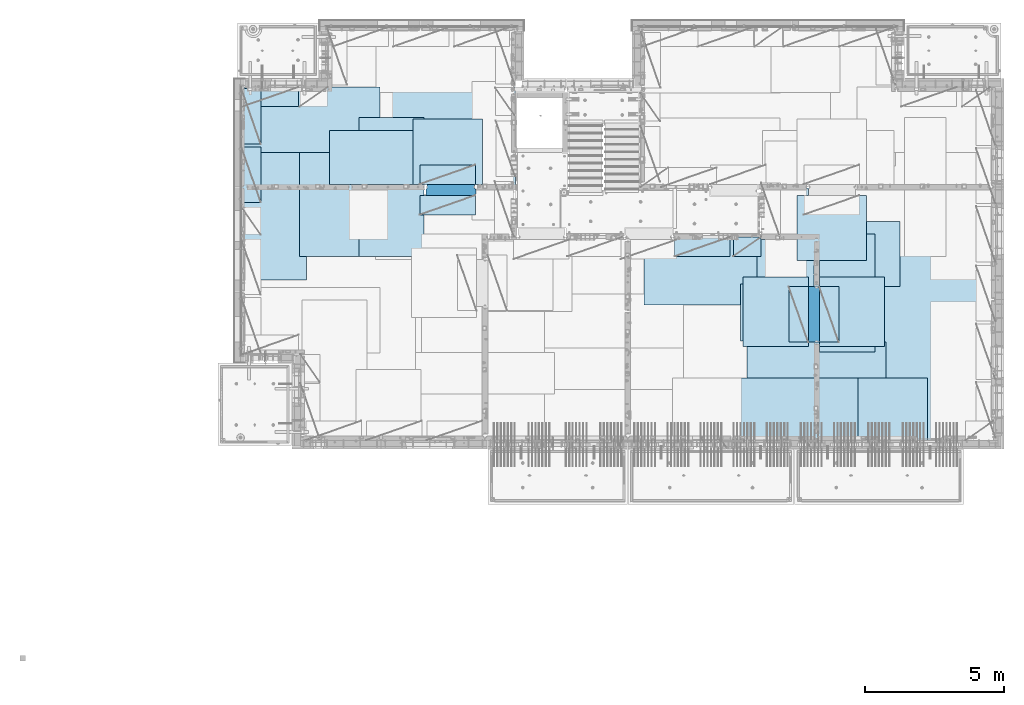
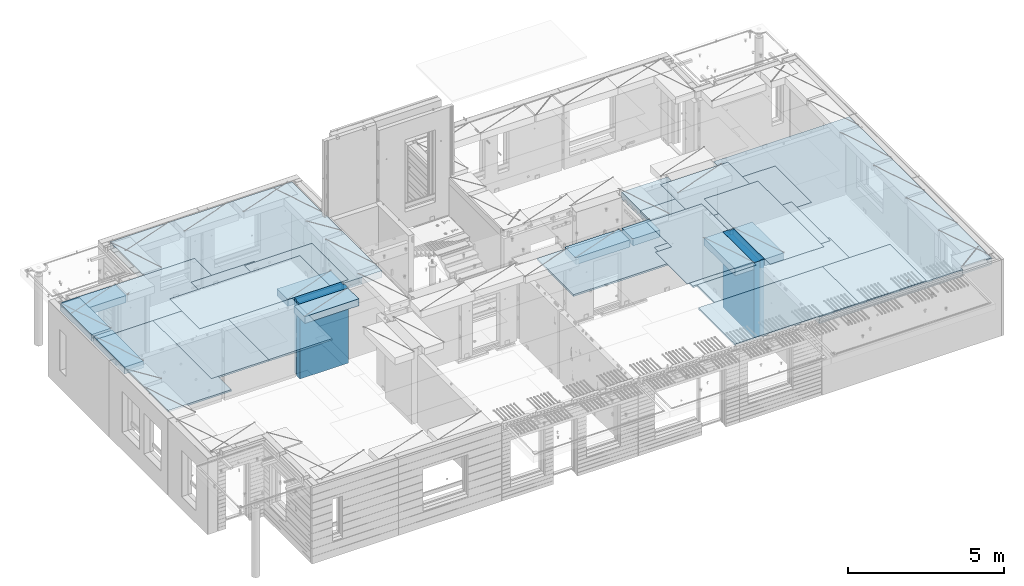
# One storey, part 203 of 352: 27 plates, 2 slabs, 25 elements without a shape of their own.
"""IFC2X3 building model written with IfcOpenShell, lengths in millimetres."""

from ifc_helpers import new_model, si_unit, frame, origin_with_axes, place, context, subcontext, project, spatial, faceted_brep, material, type_object, element, aggregate, save


model = new_model("IFC2X3")

# Units and contexts
model_context = context("Model", 3, precision=1e-05, world=origin_with_axes())
body_context = subcontext(model_context, "Body", "Model", "MODEL_VIEW")
ifc_project = project(units=[si_unit("LENGTHUNIT", "METRE", prefix="MILLI"), si_unit("AREAUNIT", "SQUARE_METRE"), si_unit("VOLUMEUNIT", "CUBIC_METRE"), si_unit("MASSUNIT", "GRAM", prefix="KILO"), si_unit("TIMEUNIT", "SECOND"), si_unit("PLANEANGLEUNIT", "RADIAN"), si_unit("SOLIDANGLEUNIT", "STERADIAN"), si_unit("THERMODYNAMICTEMPERATUREUNIT", "DEGREE_CELSIUS"), si_unit("LUMINOUSINTENSITYUNIT", "LUMEN")], contexts=[model_context])

# Site, building, storey
site_placement = place(None, origin_with_axes())
site = spatial("IfcSite", under=ifc_project, at=site_placement, CompositionType="ELEMENT")
building_placement = place(site_placement, origin_with_axes())
building = spatial("IfcBuilding", under=site, at=building_placement, CompositionType="ELEMENT")
storey_placement = place(building_placement, origin_with_axes())
storey = spatial("IfcBuildingStorey", under=building, at=storey_placement, Name="6", CompositionType="ELEMENT", Elevation=0.0)

# Assembly, slabs
assembly_1_placement = place(storey_placement, origin_with_axes())
assembly_1 = element("IfcElementAssembly", 1, at=assembly_1_placement, inside=storey, AssemblyPlace="NOTDEFINED", PredefinedType="REINFORCEMENT_UNIT")
ifc_material_1 = material(Name="CONCRETE/C30/37")
slab_type_1 = type_object("IfcSlabType", PredefinedType="NOTDEFINED")
slab_1_placement = place(assembly_1_placement, frame((7880.0, 16980.0, 99595.0), z_axis=(0.0, 1.0, 0.0), x_axis=(1.0, 0.0, 0.0)))
slab_1 = element("IfcSlab", 2, at=slab_1_placement, type_object=slab_type_1, material=ifc_material_1, PredefinedType="FLOOR", context=body_context, shape_type="Brep", body=[
    faceted_brep([(6583.68914550781, -135.0, 0.0), (6583.68914550781, 135.0, 0.0), (6583.68914550781, 135.0, 100.0), (6583.68914550781, -135.0, 100.0), (6649.99914550781, -135.0, 99.9997787475586), (6649.99914550781, 135.0, 99.9997787475586), (1.81898940354586e-12, -135.0, 1.81898940354586e-12), (-0.0001220703125, -135.0, 3600.0), (-0.0001220703125, 135.0, 3600.0), (1.81898940354586e-12, 135.0, 1.81898940354586e-12), (3110.00024414063, -135.0, 3600.0), (3110.00024414063, 135.0, 3600.0), (3110.00024414063, -135.0, 5760.0), (3110.00024414063, 135.0, 5760.0), (9850.0009765625, -135.0, 5760.0), (9850.0009765625, 135.0, 5760.0), (9850.0009765625, -135.0, 3600.0), (9850.0009765625, 135.0, 3600.0), (9870.0, -135.0, 3600.0), (9870.0, 135.0, 3600.0), (9870.0, -135.0, 0.0), (9870.0, 135.0, 0.0), (8449.99914550781, -135.0, 0.0), (8449.99914550781, 135.0, 0.0), (8449.99914550781, -135.0, 99.9997787475586), (8449.99914550781, 135.0, 99.9997787475586), (8283.68914550781, -135.0, 99.9997787475586), (8283.68914550781, 135.0, 99.9997787475586)], [[[0, 1, 2, 3]], [[4, 3, 2, 5]], [[6, 7, 8, 9]], [[7, 10, 11, 8]], [[10, 12, 13, 11]], [[12, 14, 15, 13]], [[14, 16, 17, 15]], [[16, 18, 19, 17]], [[18, 20, 21, 19]], [[21, 20, 22, 23]], [[24, 25, 23, 22]], [[26, 4, 5, 27, 25, 24]], [[1, 9, 8, 11, 13, 15, 17, 19, 21, 23, 25, 27, 5, 2]], [[6, 9, 1, 0]], [[26, 24, 22, 20, 18, 16, 14, 12, 10, 7, 6, 0, 3, 4]]]),
])
slab_type_2 = type_object("IfcSlabType", PredefinedType="NOTDEFINED")
slab_2_placement = place(assembly_1_placement, frame((28610.0, 7708.0, 99595.0), z_axis=(0.0, 1.0, 0.0), x_axis=(1.0, 0.0, 0.0)))
slab_2 = element("IfcSlab", 3, at=slab_2_placement, type_object=slab_type_2, material=ifc_material_1, PredefinedType="FLOOR", context=body_context, shape_type="Brep", body=[
    faceted_brep([(0.0, -135.0, 7430.0), (0.0, 135.0, 7430.0), (0.0, 135.0, 5722.0), (0.0, -135.0, 5722.0), (-1999.99938964844, -135.0, 7430.0), (-1999.99938964844, 135.0, 7430.0), (-1999.99938964844, -135.0, 9230.0), (-1999.99938964844, 135.0, 9230.0), (-300.000239723071, -135.0, 9230.0), (-300.000239723071, 135.0, 9230.0), (-300.00008947117, -135.0, 8972.00002930513), (-300.00008947117, 135.0, 8972.00002930513), (1385.00027673977, -135.0, 8972.00002930513), (1400.0006429507, -135.0, 8972.00002930513), (1400.0006429507, 135.0, 8972.00002930513), (1385.00027673977, 135.0, 8972.00002930513), (1400.0006429507, -135.0, 9230.0), (1400.0006429507, 135.0, 9230.0), (6449.99951171875, -135.0, 9230.0), (6449.99951171875, 135.0, 9230.0), (6449.99951171875, -135.0, 100.00023651123), (6449.99951171875, 135.0, 100.00023651123), (5318.0, -135.0, 100.0), (5318.0, 135.0, 100.0), (5318.0, -135.0, -8.68840288603678e-09), (5318.0, 135.0, -8.68840288603678e-09), (1.81898940354586e-12, -135.0, 1.81898940354586e-12), (1.81898940354586e-12, 135.0, 1.81898940354586e-12), (0.0, 135.0, 3679.99963378906), (100.00089263916, 135.0, 3679.99963378906), (100.00089263916, 135.0, 3822.0), (100.00089263916, 135.0, 5679.99963378906), (100.00089263916, 135.0, 5722.0), (100.00089263916, -135.0, 5722.0), (100.00089263916, -135.0, 3822.0), (100.00089263916, -135.0, 3679.99963378906), (0.0, -135.0, 3679.99963378906), (100.00089263916, -135.0, 5679.99963378906)], [[[0, 1, 2, 3]], [[0, 4, 5, 1]], [[4, 6, 7, 5]], [[7, 6, 8, 9]], [[8, 10, 11, 9]], [[12, 13, 14, 15, 11, 10]], [[16, 17, 14, 13]], [[18, 19, 17, 16]], [[18, 20, 21, 19]], [[20, 22, 23, 21]], [[22, 24, 25, 23]], [[24, 26, 27, 25]], [[1, 5, 7, 9, 11, 15, 14, 17, 19, 21, 23, 25, 27, 28, 29, 30, 31, 32, 2]], [[3, 2, 32, 33]], [[34, 35, 36, 26, 24, 22, 20, 18, 16, 13, 12, 10, 8, 6, 4, 0, 3, 33, 37]], [[27, 26, 36, 28]], [[35, 29, 28, 36]], [[34, 37, 31, 30, 29, 35]], [[33, 32, 31, 37]]]),
])

# Assembly, plate
assembly_2_placement = place(storey_placement, origin_with_axes())
assembly_2 = element("IfcElementAssembly", 4, at=assembly_2_placement, inside=storey, Name="Steel Assembly", AssemblyPlace="NOTDEFINED", PredefinedType="NOTDEFINED")
ifc_material_2 = material()
plate_type_1 = type_object("IfcPlateType", PredefinedType="NOTDEFINED")
plate_1_placement = place(assembly_2_placement, frame((27902.5000293051, 16680.0, 99695.1), z_axis=(1.0, 0.0, 0.0), x_axis=(0.0, -1.0, 0.0)))
plate_1 = element("IfcPlate", 5, at=plate_1_placement, type_object=plate_type_1, material=ifc_material_2, Name="1/2", context=body_context, shape_type="Brep", body=[
    faceted_brep([(0.0, -35.0, 0.0), (0.0, -35.0, 2500.0), (0.0, 35.0, 2500.0), (0.0, 35.0, 0.0), (2349.99951171875, -35.0, 2500.0), (2349.99951171875, 35.0, 2500.0), (2350.0, -35.0, 0.0), (2350.0, 35.0, 0.0)], [[[0, 1, 2, 3]], [[1, 4, 5, 2]], [[4, 6, 7, 5]], [[6, 0, 3, 7]], [[5, 7, 3, 2]], [[6, 4, 1, 0]]]),
])
aggregate(assembly_2, [plate_1])

assembly_3_placement = place(storey_placement, origin_with_axes())
assembly_3 = element("IfcElementAssembly", 6, at=assembly_3_placement, inside=storey, Name="Steel Assembly", AssemblyPlace="NOTDEFINED", PredefinedType="NOTDEFINED")
plate_2_placement = place(assembly_3_placement, frame((32610.0, 7750.0, 99695.1), z_axis=(-1.0, 3.00000001838171e-08, 0.0), x_axis=(0.0, 1.0, 0.0)))
plate_2 = element("IfcPlate", 7, at=plate_2_placement, type_object=plate_type_1, material=ifc_material_2, Name="1/2", context=body_context, shape_type="Brep", body=[
    faceted_brep([(0.0, -35.0, 0.0), (0.0, -35.0, 2500.0), (0.0, 35.0, 2500.0), (0.0, 35.0, 0.0), (2349.99951171875, -35.0, 2500.0), (2349.99951171875, 35.0, 2500.0), (2350.0, -35.0, 0.0), (2350.0, 35.0, 0.0)], [[[0, 1, 2, 3]], [[1, 4, 5, 2]], [[4, 6, 7, 5]], [[6, 0, 3, 7]], [[5, 7, 3, 2]], [[6, 4, 1, 0]]]),
])
aggregate(assembly_3, [plate_2])

assembly_4_placement = place(storey_placement, origin_with_axes())
assembly_4 = element("IfcElementAssembly", 8, at=assembly_4_placement, inside=storey, Name="Steel Assembly", AssemblyPlace="NOTDEFINED", PredefinedType="NOTDEFINED")
plate_3_placement = place(assembly_4_placement, frame((27395.0, 12730.0, 99695.1), z_axis=(-1.0, 3.00000001838171e-08, 0.0), x_axis=(0.0, 1.0, 0.0)))
plate_3 = element("IfcPlate", 9, at=plate_3_placement, type_object=plate_type_1, material=ifc_material_2, context=body_context, shape_type="Brep", body=[
    faceted_brep([(0.0, -35.0, 0.0), (0.0, -35.0, 5000.0), (0.0, 35.0, 5000.0), (0.0, 35.0, 0.0), (2349.99951171875, -35.0, 5000.0), (2349.99951171875, 35.0, 5000.0), (2350.0, -35.0, 0.0), (2350.0, 35.0, 0.0)], [[[0, 1, 2, 3]], [[1, 4, 5, 2]], [[4, 6, 7, 5]], [[6, 0, 3, 7]], [[5, 7, 3, 2]], [[6, 4, 1, 0]]]),
])
aggregate(assembly_4, [plate_3])

assembly_5_placement = place(storey_placement, origin_with_axes())
assembly_5 = element("IfcElementAssembly", 10, at=assembly_5_placement, inside=storey, Name="Steel Assembly", AssemblyPlace="NOTDEFINED", PredefinedType="NOTDEFINED")
plate_4_placement = place(assembly_5_placement, frame((28709.9995320312, 11230.0000289158, 99695.1), z_axis=(0.0, 1.0, 0.0), x_axis=(1.0, 0.0, 0.0)))
plate_4 = element("IfcPlate", 11, at=plate_4_placement, type_object=plate_type_1, material=ifc_material_2, Name="1/2", context=body_context, shape_type="Brep", body=[
    faceted_brep([(0.0, -35.0, 0.0), (0.0, -35.0, 2500.0), (0.0, 35.0, 2500.0), (0.0, 35.0, 0.0), (2349.99951171875, -35.0, 2500.0), (2349.99951171875, 35.0, 2500.0), (2350.0, -35.0, 0.0), (2350.0, 35.0, 0.0)], [[[0, 1, 2, 3]], [[1, 4, 5, 2]], [[4, 6, 7, 5]], [[6, 0, 3, 7]], [[5, 7, 3, 2]], [[6, 4, 1, 0]]]),
])
aggregate(assembly_5, [plate_4])

assembly_6_placement = place(storey_placement, origin_with_axes())
assembly_6 = element("IfcElementAssembly", 12, at=assembly_6_placement, inside=storey, Name="Steel Assembly", AssemblyPlace="NOTDEFINED", PredefinedType="NOTDEFINED")
plate_5_placement = place(assembly_6_placement, frame((25959.9995320312, 11230.0000289158, 99695.1), z_axis=(0.0, 1.0, 0.0), x_axis=(1.0, 0.0, 0.0)))
plate_5 = element("IfcPlate", 13, at=plate_5_placement, type_object=plate_type_1, material=ifc_material_2, Name="1/2", context=body_context, shape_type="Brep", body=[
    faceted_brep([(0.0, -35.0, 0.0), (0.0, -35.0, 2500.0), (0.0, 35.0, 2500.0), (0.0, 35.0, 0.0), (2349.99951171875, -35.0, 2500.0), (2349.99951171875, 35.0, 2500.0), (2350.0, -35.0, 0.0), (2350.0, 35.0, 0.0)], [[[0, 1, 2, 3]], [[1, 4, 5, 2]], [[4, 6, 7, 5]], [[6, 0, 3, 7]], [[5, 7, 3, 2]], [[6, 4, 1, 0]]]),
])
aggregate(assembly_6, [plate_5])

assembly_7_placement = place(storey_placement, origin_with_axes())
assembly_7 = element("IfcElementAssembly", 14, at=assembly_7_placement, inside=storey, Name="Steel Assembly", AssemblyPlace="NOTDEFINED", PredefinedType="NOTDEFINED")
plate_6_placement = place(assembly_7_placement, frame((7880.0, 20580.0, 99695.1), z_axis=(1.0, 0.0, 0.0), x_axis=(0.0, -1.0, 0.0)))
plate_6 = element("IfcPlate", 15, at=plate_6_placement, type_object=plate_type_1, material=ifc_material_2, context=body_context, shape_type="Brep", body=[
    faceted_brep([(0.0, -35.0, 0.0), (0.0, -35.0, 5000.0), (0.0, 35.0, 5000.0), (0.0, 35.0, 0.0), (2349.99951171875, -35.0, 5000.0), (2349.99951171875, 35.0, 5000.0), (2350.0, -35.0, 0.0), (2350.0, 35.0, 0.0)], [[[0, 1, 2, 3]], [[1, 4, 5, 2]], [[4, 6, 7, 5]], [[6, 0, 3, 7]], [[5, 7, 3, 2]], [[6, 4, 1, 0]]]),
])
aggregate(assembly_7, [plate_6])

assembly_8_placement = place(storey_placement, origin_with_axes())
assembly_8 = element("IfcElementAssembly", 16, at=assembly_8_placement, inside=storey, Name="Steel Assembly", AssemblyPlace="NOTDEFINED", PredefinedType="NOTDEFINED")
plate_7_placement = place(assembly_8_placement, frame((14063.69, 19430.0, 99695.1), z_axis=(1.0, 0.0, 0.0), x_axis=(0.0, -1.0, 0.0)))
plate_7 = element("IfcPlate", 17, at=plate_7_placement, type_object=plate_type_1, material=ifc_material_2, Name="1/2", context=body_context, shape_type="Brep", body=[
    faceted_brep([(0.0, -35.0, 0.0), (0.0, -35.0, 2500.0), (0.0, 35.0, 2500.0), (0.0, 35.0, 0.0), (2349.99951171875, -35.0, 2500.0), (2349.99951171875, 35.0, 2500.0), (2350.0, -35.0, 0.0), (2350.0, 35.0, 0.0)], [[[0, 1, 2, 3]], [[1, 4, 5, 2]], [[4, 6, 7, 5]], [[6, 0, 3, 7]], [[5, 7, 3, 2]], [[6, 4, 1, 0]]]),
])
aggregate(assembly_8, [plate_7])

assembly_9_placement = place(storey_placement, origin_with_axes())
assembly_9 = element("IfcElementAssembly", 18, at=assembly_9_placement, inside=storey, Name="Steel Assembly", AssemblyPlace="NOTDEFINED", PredefinedType="NOTDEFINED")
plate_8_placement = place(assembly_9_placement, frame((31610.0, 13388.0, 99695.1), z_axis=(-1.0, 3.00000001838171e-08, 0.0), x_axis=(0.0, 1.0, 0.0)))
plate_8 = element("IfcPlate", 19, at=plate_8_placement, type_object=plate_type_1, material=ifc_material_2, context=body_context, shape_type="Brep", body=[
    faceted_brep([(0.0, -35.0, 0.0), (0.0, -35.0, 5000.0), (0.0, 35.0, 5000.0), (0.0, 35.0, 0.0), (2349.99951171875, -35.0, 5000.0), (2349.99951171875, 35.0, 5000.0), (2350.0, -35.0, 0.0), (2350.0, 35.0, 0.0)], [[[0, 1, 2, 3]], [[1, 4, 5, 2]], [[4, 6, 7, 5]], [[6, 0, 3, 7]], [[5, 7, 3, 2]], [[6, 4, 1, 0]]]),
])
aggregate(assembly_9, [plate_8])

assembly_10_placement = place(storey_placement, origin_with_axes())
assembly_10 = element("IfcElementAssembly", 20, at=assembly_10_placement, inside=storey, Name="Steel Assembly", AssemblyPlace="NOTDEFINED", PredefinedType="NOTDEFINED")
plate_9_placement = place(assembly_10_placement, frame((31110.0, 9038.0, 99695.1), z_axis=(-1.0, 3.00000001838171e-08, 0.0), x_axis=(0.0, 1.0, 0.0)))
plate_9 = element("IfcPlate", 21, at=plate_9_placement, type_object=plate_type_1, material=ifc_material_2, context=body_context, shape_type="Brep", body=[
    faceted_brep([(0.0, -35.0, 0.0), (0.0, -35.0, 5000.0), (0.0, 35.0, 5000.0), (0.0, 35.0, 0.0), (2349.99951171875, -35.0, 5000.0), (2349.99951171875, 35.0, 5000.0), (2350.0, -35.0, 0.0), (2350.0, 35.0, 0.0)], [[[0, 1, 2, 3]], [[1, 4, 5, 2]], [[4, 6, 7, 5]], [[6, 0, 3, 7]], [[5, 7, 3, 2]], [[6, 4, 1, 0]]]),
])
aggregate(assembly_10, [plate_9])

assembly_11_placement = place(storey_placement, origin_with_axes())
assembly_11 = element("IfcElementAssembly", 22, at=assembly_11_placement, inside=storey, Name="Steel Assembly", AssemblyPlace="NOTDEFINED", PredefinedType="NOTDEFINED")
plate_10_placement = place(assembly_11_placement, frame((30510.0, 7750.0, 99695.1), z_axis=(-1.0, 3.00000001838171e-08, 0.0), x_axis=(0.0, 1.0, 0.0)))
plate_10 = element("IfcPlate", 23, at=plate_10_placement, type_object=plate_type_1, material=ifc_material_2, context=body_context, shape_type="Brep", body=[
    faceted_brep([(0.0, -35.0, 0.0), (0.0, -35.0, 5000.0), (0.0, 35.0, 5000.0), (0.0, 35.0, 0.0), (2349.99951171875, -35.0, 5000.0), (2349.99951171875, 35.0, 5000.0), (2350.0, -35.0, 0.0), (2350.0, 35.0, 0.0)], [[[0, 1, 2, 3]], [[1, 4, 5, 2]], [[4, 6, 7, 5]], [[6, 0, 3, 7]], [[5, 7, 3, 2]], [[6, 4, 1, 0]]]),
])
aggregate(assembly_11, [plate_10])

assembly_12_placement = place(storey_placement, origin_with_axes())
assembly_12 = element("IfcElementAssembly", 24, at=assembly_12_placement, inside=storey, Name="Steel Assembly", AssemblyPlace="NOTDEFINED", PredefinedType="NOTDEFINED")
plate_11_placement = place(assembly_12_placement, frame((10230.0, 18627.0, 99695.1), z_axis=(0.0, -1.0, 0.0), x_axis=(-1.0, 3.00000001838171e-08, 0.0)))
plate_11 = element("IfcPlate", 25, at=plate_11_placement, type_object=plate_type_1, material=ifc_material_2, context=body_context, shape_type="Brep", body=[
    faceted_brep([(0.0, -35.0, 0.0), (0.0, -35.0, 5000.0), (0.0, 35.0, 5000.0), (0.0, 35.0, 0.0), (2349.99951171875, -35.0, 5000.0), (2349.99951171875, 35.0, 5000.0), (2350.0, -35.0, 0.0), (2350.0, 35.0, 0.0)], [[[0, 1, 2, 3]], [[1, 4, 5, 2]], [[4, 6, 7, 5]], [[6, 0, 3, 7]], [[5, 7, 3, 2]], [[6, 4, 1, 0]]]),
])
aggregate(assembly_12, [plate_11])

assembly_13_placement = place(storey_placement, origin_with_axes())
assembly_13 = element("IfcElementAssembly", 26, at=assembly_13_placement, inside=storey, Name="Steel Assembly", AssemblyPlace="NOTDEFINED", PredefinedType="NOTDEFINED")
plate_12_placement = place(assembly_13_placement, frame((14463.69, 19480.0, 99695.1), z_axis=(0.0, -1.0, 0.0), x_axis=(-1.0, 3.00000001838171e-08, 0.0)))
plate_12 = element("IfcPlate", 27, at=plate_12_placement, type_object=plate_type_1, material=ifc_material_2, context=body_context, shape_type="Brep", body=[
    faceted_brep([(0.0, -35.0, 0.0), (0.0, -35.0, 5000.0), (0.0, 35.0, 5000.0), (0.0, 35.0, 0.0), (2349.99951171875, -35.0, 5000.0), (2349.99951171875, 35.0, 5000.0), (2350.0, -35.0, 0.0), (2350.0, 35.0, 0.0)], [[[0, 1, 2, 3]], [[1, 4, 5, 2]], [[4, 6, 7, 5]], [[6, 0, 3, 7]], [[5, 7, 3, 2]], [[6, 4, 1, 0]]]),
])
aggregate(assembly_13, [plate_12])

assembly_14_placement = place(storey_placement, origin_with_axes())
assembly_14 = element("IfcElementAssembly", 28, at=assembly_14_placement, inside=storey, Name="Steel Assembly", AssemblyPlace="NOTDEFINED", PredefinedType="NOTDEFINED")
plate_13_placement = place(assembly_14_placement, frame((12330.0, 19480.0, 99695.1), z_axis=(0.0, -1.0, 0.0), x_axis=(-1.0, 3.00000001838171e-08, 0.0)))
plate_13 = element("IfcPlate", 29, at=plate_13_placement, type_object=plate_type_1, material=ifc_material_2, context=body_context, shape_type="Brep", body=[
    faceted_brep([(0.0, -35.0, 0.0), (0.0, -35.0, 5000.0), (0.0, 35.0, 5000.0), (0.0, 35.0, 0.0), (2349.99951171875, -35.0, 5000.0), (2349.99951171875, 35.0, 5000.0), (2350.0, -35.0, 0.0), (2350.0, 35.0, 0.0)], [[[0, 1, 2, 3]], [[1, 4, 5, 2]], [[4, 6, 7, 5]], [[6, 0, 3, 7]], [[5, 7, 3, 2]], [[6, 4, 1, 0]]]),
])
aggregate(assembly_14, [plate_13])

assembly_15_placement = place(storey_placement, origin_with_axes())
assembly_15 = element("IfcElementAssembly", 30, at=assembly_15_placement, inside=storey, Name="Steel Assembly", AssemblyPlace="NOTDEFINED", PredefinedType="NOTDEFINED")
plate_type_2 = type_object("IfcPlateType", PredefinedType="NOTDEFINED")
plate_14_placement = place(assembly_15_placement, frame((7879.99987792969, 20530.0, 99595.3), z_axis=(1.0, 0.0, 0.0), x_axis=(0.0, -1.0, 0.0)))
plate_14 = element("IfcPlate", 31, at=plate_14_placement, type_object=plate_type_2, material=ifc_material_2, Name="RE1", context=body_context, shape_type="Brep", body=[
    faceted_brep([(1.81898940354586e-12, -135.0, 1.81898940354586e-12), (0.0, -135.0, 699.999999999996), (0.0, 135.0, 699.999999999996), (1.81898940354586e-12, 135.0, 1.81898940354586e-12), (1999.99951171875, -135.0, 699.999999999993), (1999.99951171875, 135.0, 699.999999999993), (2000.0, -135.0, -3.63797880709171e-12), (2000.0, 135.0, -3.63797880709171e-12)], [[[0, 1, 2, 3]], [[1, 4, 5, 2]], [[4, 6, 7, 5]], [[6, 0, 3, 7]], [[5, 7, 3, 2]], [[6, 4, 1, 0]]]),
])
aggregate(assembly_15, [plate_14])

assembly_16_placement = place(storey_placement, origin_with_axes())
assembly_16 = element("IfcElementAssembly", 32, at=assembly_16_placement, inside=storey, Name="Steel Assembly", AssemblyPlace="NOTDEFINED", PredefinedType="NOTDEFINED")
plate_15_placement = place(assembly_16_placement, frame((28710.2298779297, 13388.0, 99595.3), z_axis=(1.0, 0.0, 0.0), x_axis=(0.0, -1.0, 0.0)))
plate_15 = element("IfcPlate", 33, at=plate_15_placement, type_object=plate_type_2, material=ifc_material_2, Name="RE1", context=body_context, shape_type="Brep", body=[
    faceted_brep([(1.81898940354586e-12, -135.0, 1.81898940354586e-12), (0.0, -135.0, 699.999999999996), (0.0, 135.0, 699.999999999996), (1.81898940354586e-12, 135.0, 1.81898940354586e-12), (1999.99951171875, -135.0, 699.999999999993), (1999.99951171875, 135.0, 699.999999999993), (2000.0, -135.0, -3.63797880709171e-12), (2000.0, 135.0, -3.63797880709171e-12)], [[[0, 1, 2, 3]], [[1, 4, 5, 2]], [[4, 6, 7, 5]], [[6, 0, 3, 7]], [[5, 7, 3, 2]], [[6, 4, 1, 0]]]),
])
aggregate(assembly_16, [plate_15])

assembly_17_placement = place(storey_placement, origin_with_axes())
assembly_17 = element("IfcElementAssembly", 34, at=assembly_17_placement, inside=storey, Name="Steel Assembly", AssemblyPlace="NOTDEFINED", PredefinedType="NOTDEFINED")
plate_16_placement = place(assembly_17_placement, frame((28310.0001220703, 11388.0, 99595.3), z_axis=(-1.0, 3.00000001838171e-08, 0.0), x_axis=(0.0, 1.0, 0.0)))
plate_16 = element("IfcPlate", 35, at=plate_16_placement, type_object=plate_type_2, material=ifc_material_2, Name="RE1", context=body_context, shape_type="Brep", body=[
    faceted_brep([(1.81898940354586e-12, -135.0, 1.81898940354586e-12), (0.0, -135.0, 699.999999999996), (0.0, 135.0, 699.999999999996), (1.81898940354586e-12, 135.0, 1.81898940354586e-12), (1999.99951171875, -135.0, 699.999999999993), (1999.99951171875, 135.0, 699.999999999993), (2000.0, -135.0, -3.63797880709171e-12), (2000.0, 135.0, -3.63797880709171e-12)], [[[0, 1, 2, 3]], [[1, 4, 5, 2]], [[4, 6, 7, 5]], [[6, 0, 3, 7]], [[5, 7, 3, 2]], [[6, 4, 1, 0]]]),
])
aggregate(assembly_17, [plate_16])

assembly_18_placement = place(storey_placement, origin_with_axes())
assembly_18 = element("IfcElementAssembly", 36, at=assembly_18_placement, inside=storey, Name="Steel Assembly", AssemblyPlace="NOTDEFINED", PredefinedType="NOTDEFINED")
plate_17_placement = place(assembly_18_placement, frame((14313.6908542386, 17080.0001036336, 99595.3), z_axis=(0.0, 1.0, 0.0), x_axis=(1.0, 0.0, 0.0)))
plate_17 = element("IfcPlate", 37, at=plate_17_placement, type_object=plate_type_2, material=ifc_material_2, Name="RE1", context=body_context, shape_type="Brep", body=[
    faceted_brep([(1.81898940354586e-12, -135.0, 1.81898940354586e-12), (0.0, -135.0, 699.999999999996), (0.0, 135.0, 699.999999999996), (1.81898940354586e-12, 135.0, 1.81898940354586e-12), (1999.99951171875, -135.0, 699.999999999993), (1999.99951171875, 135.0, 699.999999999993), (2000.0, -135.0, -3.63797880709171e-12), (2000.0, 135.0, -3.63797880709171e-12)], [[[0, 1, 2, 3]], [[1, 4, 5, 2]], [[4, 6, 7, 5]], [[6, 0, 3, 7]], [[5, 7, 3, 2]], [[6, 4, 1, 0]]]),
])
aggregate(assembly_18, [plate_17])

assembly_19_placement = place(storey_placement, origin_with_axes())
assembly_19 = element("IfcElementAssembly", 38, at=assembly_19_placement, inside=storey, Name="Steel Assembly", AssemblyPlace="NOTDEFINED", PredefinedType="NOTDEFINED")
plate_18_placement = place(assembly_19_placement, frame((16313.6891457614, 16679.9998963664, 99595.3), z_axis=(0.0, -1.0, 0.0), x_axis=(-1.0, 3.00000001838171e-08, 0.0)))
plate_18 = element("IfcPlate", 39, at=plate_18_placement, type_object=plate_type_2, material=ifc_material_2, Name="RE1", context=body_context, shape_type="Brep", body=[
    faceted_brep([(1.81898940354586e-12, -135.0, 1.81898940354586e-12), (0.0, -135.0, 699.999999999996), (0.0, 135.0, 699.999999999996), (1.81898940354586e-12, 135.0, 1.81898940354586e-12), (1999.99951171875, -135.0, 699.999999999993), (1999.99951171875, 135.0, 699.999999999993), (2000.0, -135.0, -3.63797880709171e-12), (2000.0, 135.0, -3.63797880709171e-12)], [[[0, 1, 2, 3]], [[1, 4, 5, 2]], [[4, 6, 7, 5]], [[6, 0, 3, 7]], [[5, 7, 3, 2]], [[6, 4, 1, 0]]]),
])
aggregate(assembly_19, [plate_18])

assembly_20_placement = place(storey_placement, origin_with_axes())
assembly_20 = element("IfcElementAssembly", 40, at=assembly_20_placement, inside=storey, Name="Steel Assembly", AssemblyPlace="NOTDEFINED", PredefinedType="NOTDEFINED")
plate_19_placement = place(assembly_20_placement, frame((25494.9991457614, 15179.9998963664, 99595.3), z_axis=(0.0, -1.0, 0.0), x_axis=(-1.0, 3.00000001838171e-08, 0.0)))
plate_19 = element("IfcPlate", 41, at=plate_19_placement, type_object=plate_type_2, material=ifc_material_2, Name="RE1", context=body_context, shape_type="Brep", body=[
    faceted_brep([(1.81898940354586e-12, -135.0, 1.81898940354586e-12), (0.0, -135.0, 699.999999999996), (0.0, 135.0, 699.999999999996), (1.81898940354586e-12, 135.0, 1.81898940354586e-12), (1999.99951171875, -135.0, 699.999999999993), (1999.99951171875, 135.0, 699.999999999993), (2000.0, -135.0, -3.63797880709171e-12), (2000.0, 135.0, -3.63797880709171e-12)], [[[0, 1, 2, 3]], [[1, 4, 5, 2]], [[4, 6, 7, 5]], [[6, 0, 3, 7]], [[5, 7, 3, 2]], [[6, 4, 1, 0]]]),
])
aggregate(assembly_20, [plate_19])

assembly_21_placement = place(storey_placement, origin_with_axes())
assembly_21 = element("IfcElementAssembly", 42, at=assembly_21_placement, inside=storey, Name="Steel Assembly", AssemblyPlace="NOTDEFINED", PredefinedType="NOTDEFINED")
plate_20_placement = place(assembly_21_placement, frame((26610.0, 15180.0000000707, 99595.3), z_axis=(0.0, -1.0, 0.0), x_axis=(-1.0, 3.00000001838171e-08, 0.0)))
plate_20 = element("IfcPlate", 43, at=plate_20_placement, type_object=plate_type_2, material=ifc_material_2, Name="RE1_1/2", context=body_context, shape_type="Brep", body=[
    faceted_brep([(1.81898940354586e-12, -135.0, 1.81898940354586e-12), (0.0, -135.0, 699.999999999996), (0.0, 135.0, 699.999999999996), (1.81898940354586e-12, 135.0, 1.81898940354586e-12), (999.99951171875, -135.0, 700.0), (999.99951171875, 135.0, 700.0), (1000.0, -135.0, 0.0), (1000.0, 135.0, 0.0)], [[[0, 1, 2, 3]], [[1, 4, 5, 2]], [[4, 6, 7, 5]], [[6, 0, 3, 7]], [[5, 7, 3, 2]], [[6, 4, 1, 0]]]),
])
aggregate(assembly_21, [plate_20])

assembly_22_placement = place(storey_placement, origin_with_axes())
assembly_22 = element("IfcElementAssembly", 44, at=assembly_22_placement, inside=storey, Name="Steel Assembly", AssemblyPlace="NOTDEFINED", PredefinedType="NOTDEFINED")
plate_21_placement = place(assembly_22_placement, frame((9935.0, 20580.0001220703, 99595.3), z_axis=(0.0, -1.0, 0.0), x_axis=(-1.0, 3.00000001838171e-08, 0.0)))
plate_21 = element("IfcPlate", 45, at=plate_21_placement, type_object=plate_type_2, material=ifc_material_2, Name="RE1", context=body_context, shape_type="Brep", body=[
    faceted_brep([(1.81898940354586e-12, -135.0, 1.81898940354586e-12), (0.0, -135.0, 699.999999999996), (0.0, 135.0, 699.999999999996), (1.81898940354586e-12, 135.0, 1.81898940354586e-12), (1999.99951171875, -135.0, 699.999999999993), (1999.99951171875, 135.0, 699.999999999993), (2000.0, -135.0, -3.63797880709171e-12), (2000.0, 135.0, -3.63797880709171e-12)], [[[0, 1, 2, 3]], [[1, 4, 5, 2]], [[4, 6, 7, 5]], [[6, 0, 3, 7]], [[5, 7, 3, 2]], [[6, 4, 1, 0]]]),
])
aggregate(assembly_22, [plate_21])

assembly_23_placement = place(storey_placement, origin_with_axes())
assembly_23 = element("IfcElementAssembly", 46, at=assembly_23_placement, inside=storey, Name="Steel Assembly", AssemblyPlace="NOTDEFINED", PredefinedType="NOTDEFINED")
plate_22_placement = place(assembly_23_placement, frame((7879.99987792969, 18430.0, 99595.3), z_axis=(1.0, 0.0, 0.0), x_axis=(0.0, -1.0, 0.0)))
plate_22 = element("IfcPlate", 47, at=plate_22_placement, type_object=plate_type_2, material=ifc_material_2, Name="RE1", context=body_context, shape_type="Brep", body=[
    faceted_brep([(1.81898940354586e-12, -135.0, 1.81898940354586e-12), (0.0, -135.0, 699.999999999996), (0.0, 135.0, 699.999999999996), (1.81898940354586e-12, 135.0, 1.81898940354586e-12), (1999.99951171875, -135.0, 699.999999999993), (1999.99951171875, 135.0, 699.999999999993), (2000.0, -135.0, -3.63797880709171e-12), (2000.0, 135.0, -3.63797880709171e-12)], [[[0, 1, 2, 3]], [[1, 4, 5, 2]], [[4, 6, 7, 5]], [[6, 0, 3, 7]], [[5, 7, 3, 2]], [[6, 4, 1, 0]]]),
])
aggregate(assembly_23, [plate_22])

# Plate
plate_type_3 = type_object("IfcPlateType", PredefinedType="NOTDEFINED")
plate_23_placement = place(assembly_1_placement, frame((11048.0003525539, 17079.9997757405, 99725.45), z_axis=(0.0, 1.0, 0.0), x_axis=(1.0, 0.0, 0.0)))
plate_23 = element("IfcPlate", 48, at=plate_23_placement, type_object=plate_type_3, material=ifc_material_2, context=body_context, shape_type="Brep", body=[
    faceted_brep([(0.0, -5.0, 0.0), (0.0, -5.0, 1939.99963378906), (0.0, 5.0, 1939.99963378906), (0.0, 5.0, 0.0), (4827.9990234375, -5.0, 1939.99963378906), (4827.9990234375, 5.0, 1939.99963378906), (4827.9990234375, -5.0, 0.0), (4827.9990234375, 5.0, 0.0)], [[[0, 1, 2, 3]], [[1, 4, 5, 2]], [[4, 6, 7, 5]], [[6, 0, 3, 7]], [[5, 7, 3, 2]], [[6, 4, 1, 0]]]),
])

plate_type_4 = type_object("IfcPlateType", PredefinedType="NOTDEFINED")
plate_24_placement = place(assembly_1_placement, frame((28710.0010086818, 11039.9998138874, 99725.45), z_axis=(0.0, 1.0, 0.0), x_axis=(1.0, 0.0, 0.0)))
plate_24 = element("IfcPlate", 49, at=plate_24_placement, type_object=plate_type_4, material=ifc_material_2, context=body_context, shape_type="Brep", body=[
    faceted_brep([(0.0, -5.0, 0.0), (-0.00100868183653802, -5.0, 4240.0), (-0.00100868183653802, 5.0, 4240.0), (0.0, 5.0, 0.0), (2000.0, -5.0, 4240.0), (2000.0, 5.0, 4240.0), (2000.0, -5.0, 0.0), (2000.0, 5.0, 0.0)], [[[0, 1, 2, 3]], [[1, 4, 5, 2]], [[4, 6, 7, 5]], [[6, 0, 3, 7]], [[5, 7, 3, 2]], [[6, 4, 1, 0]]]),
])

plate_type_5 = type_object("IfcPlateType", PredefinedType="NOTDEFINED")
plate_25_placement = place(assembly_1_placement, frame((25860.0006272121, 11525.9998749226, 99725.45), z_axis=(1.0, 0.0, 0.0), x_axis=(0.0, -1.0, 0.0)))
plate_25 = element("IfcPlate", 50, at=plate_25_placement, type_object=plate_type_5, material=ifc_material_2, context=body_context, shape_type="Brep", body=[
    faceted_brep([(92.0000076293945, -5.0, 2449.99937278789), (92.0000076293945, 5.0, 2449.99937278789), (-1861.99975886647, 5.0, 2449.99937278789), (-1861.99975886647, -5.0, 2449.99937278789), (-1861.99975886647, -5.0, 2649.99937278789), (-1861.99975886647, 5.0, 2649.99939842034), (92.0000076293945, -5.0, 0.0), (0.0, -5.0, 0.0), (0.0, 5.0, 0.0), (92.0000076293945, 5.0, 0.0), (-1954.00048828125, -5.0, 0.0), (-1954.00048828125, 5.0, 0.0), (-1954.00048828125, -5.0, 600.000366210938), (-1954.00048828125, 5.0, 600.000366210938), (-3554.0, -5.0, 600.000366210938), (-3554.0, 5.0, 600.000366210938), (-3554.0, -5.0, 2649.99951171875), (-3554.0, 5.0, 2649.99951171875)], [[[0, 1, 2, 3]], [[4, 3, 2, 5]], [[6, 7, 8, 9]], [[7, 10, 11, 8]], [[10, 12, 13, 11]], [[12, 14, 15, 13]], [[14, 16, 17, 15]], [[17, 16, 4, 5]], [[1, 9, 8, 11, 13, 15, 17, 5, 2]], [[6, 9, 1, 0]], [[16, 14, 12, 10, 7, 6, 0, 3, 4]]]),
])

aggregate(assembly_1, [plate_24, plate_25, plate_23, slab_2, slab_1])

# Assembly, plate
assembly_24_placement = place(storey_placement, origin_with_axes())
assembly_24 = element("IfcElementAssembly", 51, at=assembly_24_placement, inside=storey, Name="Steel Assembly", AssemblyPlace="NOTDEFINED", PredefinedType="NOTDEFINED")
ifc_material_3 = material()
plate_type_6 = type_object("IfcPlateType", PredefinedType="NOTDEFINED")
plate_26_placement = place(assembly_24_placement, frame((14530.0, 16680.0, 98255.6000003815), z_axis=(0.0, 1.0, 0.0), x_axis=(1.0, 0.0, 0.0)))
plate_26 = element("IfcPlate", 52, at=plate_26_placement, type_object=plate_type_6, material=ifc_material_3, context=body_context, shape_type="Brep", body=[
    faceted_brep([(1749.99914550781, -1475.0, 400.0), (1749.99914550781, -1475.0, 243.000000000004), (1749.99914550781, 1475.0, 243.000000000004), (1749.99914550781, 1475.0, 400.0), (1799.99914550781, -1475.0, 221.333333333332), (1799.99914550781, 1475.0, 221.333333333332), (30.0, -1475.0, 400.0), (30.0, 1475.0, 400.0), (30.0, 1475.0, 243.0), (30.0, -1475.0, 243.0), (0.0, 1475.0, 230.0), (0.0, -1475.0, 230.0), (0.0, 1475.0, 0.0), (0.0, -1475.0, 0.0), (1799.99914550781, -1475.0, 3.63797880709171e-12), (1799.99914550781, 1475.0, 3.63797880709171e-12)], [[[0, 1, 2, 3]], [[4, 5, 2, 1]], [[6, 7, 8, 9]], [[9, 8, 10, 11]], [[12, 13, 11, 10]], [[14, 13, 12, 15]], [[0, 6, 9, 11, 13, 14, 4, 1]], [[7, 6, 0, 3]], [[15, 12, 10, 8, 7, 3, 2, 5]], [[14, 15, 5, 4]]]),
])
aggregate(assembly_24, [plate_26])

assembly_25_placement = place(storey_placement, origin_with_axes())
assembly_25 = element("IfcElementAssembly", 53, at=assembly_25_placement, inside=storey, Name="Steel Assembly", AssemblyPlace="NOTDEFINED", PredefinedType="NOTDEFINED")
plate_27_placement = place(assembly_25_placement, frame((28710.0, 11388.0, 98255.6000003815), z_axis=(-1.0, 3.00000001838171e-08, 0.0), x_axis=(0.0, 1.0, 0.0)))
plate_27 = element("IfcPlate", 54, at=plate_27_placement, type_object=plate_type_6, material=ifc_material_3, context=body_context, shape_type="Brep", body=[
    faceted_brep([(0.0, -1475.0, 170.000000230655), (0.0, 1475.0, 170.000000368096), (30.0, 1475.0, 156.999999999998), (30.0, -1475.0, 156.999999999998), (29.9999998430139, -1475.0, 0.0), (29.9999998430139, 1475.0, 0.0), (0.0, -1475.0, 400.0), (1999.99963378906, -1475.0, 400.0), (1999.99963378906, 1475.0, 400.0), (0.0, 1475.0, 400.0), (1999.99963378906, -1475.0, 170.000003831468), (1999.99963378906, 1475.0, 170.000003831468), (1969.99962494722, -1475.0, 157.0), (1969.99962494722, 1475.0, 157.0), (1969.99962494722, -1475.0, 0.0), (1969.99962494722, 1475.0, 0.0)], [[[0, 1, 2, 3]], [[4, 3, 2, 5]], [[6, 7, 8, 9]], [[8, 7, 10, 11]], [[12, 13, 11, 10]], [[14, 15, 13, 12]], [[15, 14, 4, 5]], [[1, 9, 8, 11, 13, 15, 5, 2]], [[6, 9, 1, 0]], [[14, 12, 10, 7, 6, 0, 3, 4]]]),
])
aggregate(assembly_25, [plate_27])

save(model, "model.ifc")
